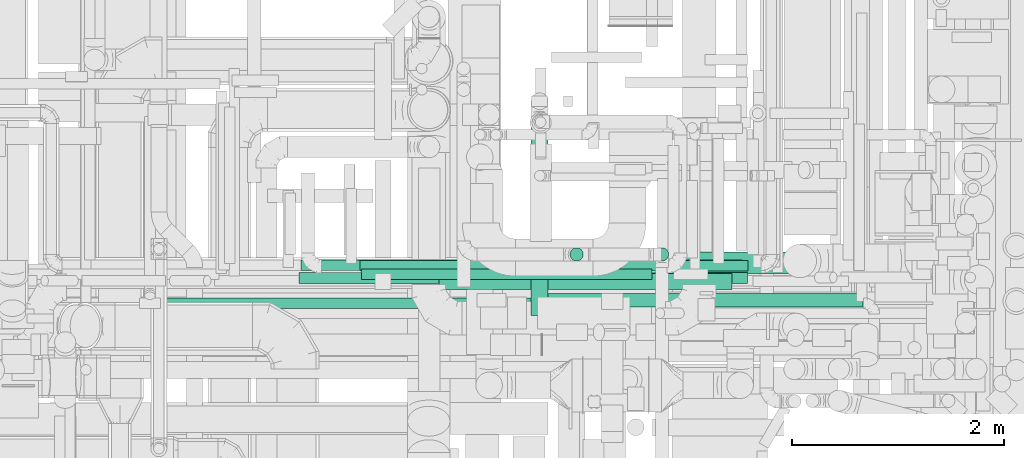
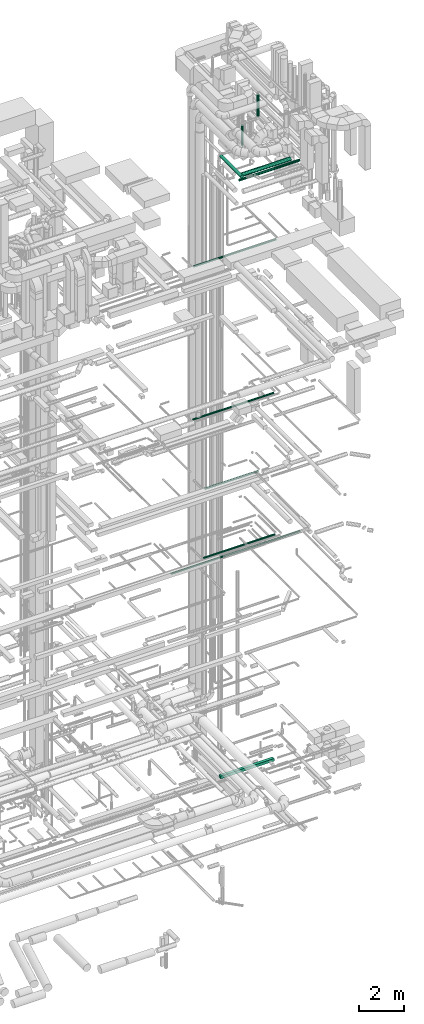
# One storey, part 65 of 337: 11 flow segments.
"""IFC2X3 building model written with IfcOpenShell, lengths in millimetres."""

import ifcopenshell
import ifcopenshell.guid

model = None  # the IFC model being written
_history = None  # IfcOwnerHistory: only IFC2X3 demands one
_inside = {}  # id of a spatial element -> (the spatial element, [elements in it])
_under = {}  # id of a project, library or spatial element -> (it, [spatial elements below it])
_declared = {}  # id of a project -> (the project, [libraries it declares])
_typed = {}  # id of a type object -> (the type object, [elements of that type])
_made_of = {}  # id of a material, layer set ... -> (it, [elements and type objects made of it])


def new_model(schema):
    """Start an empty IFC model of exactly this schema.

    Asked for "IFC4X3", IfcOpenShell would pick the latest addendum, in which some entities
    have other attributes; the version numbers below select the first issue.
    IFC2X3 requires an IfcOwnerHistory on every rooted entity: one is made here for all.
    """
    global model, _history
    if schema == "IFC4X3":
        model = ifcopenshell.file(schema_version=(4, 3, 0, 0))
    else:
        model = ifcopenshell.file(schema=schema)
    _inside.clear()
    _under.clear()
    _declared.clear()
    _typed.clear()
    _made_of.clear()
    _history = None
    if model.schema == "IFC2X3":
        org = make("IfcOrganization", Name="unknown")
        user = make(
            "IfcPersonAndOrganization",
            ThePerson=make("IfcPerson", FamilyName="unknown"),
            TheOrganization=org,
        )
        app = make(
            "IfcApplication",
            ApplicationDeveloper=org,
            Version="unknown",
            ApplicationFullName="unknown",
            ApplicationIdentifier="unknown",
        )
        _history = make(
            "IfcOwnerHistory",
            OwningUser=user,
            OwningApplication=app,
            ChangeAction="ADDED",
            CreationDate=0,
        )
    return model


def make(cls, **values):
    """One entity of the class cls with the attributes given. An attribute that is None is left unset."""
    return model.create_entity(
        cls, **{name: value for name, value in values.items() if value is not None}
    )


def entity(cls, *values):
    """Any entity or typed value of the class cls, its attributes in the order of the schema. None: left unset."""
    e = model.create_entity(cls)
    for i, value in enumerate(values):
        if value is not None:
            e[i] = value
    return e


def rooted(cls, **values):
    """An entity with a GlobalId (a new one), such as an element, a storey or a relation."""
    return make(cls, GlobalId=ifcopenshell.guid.new(), OwnerHistory=_history, **values)


def si_unit(unit_type, name, prefix=None):
    """IfcSIUnit, for example si_unit("LENGTHUNIT", "METRE", prefix="MILLI")."""
    return make("IfcSIUnit", UnitType=unit_type, Prefix=prefix, Name=name)


def converted_unit(unit_type, name, factor, base, dimensions=None, offset=None):
    """IfcConversionBasedUnit, such as the inch: factor (a typed value) times the base unit."""
    return make(
        "IfcConversionBasedUnit"
        if offset is None
        else "IfcConversionBasedUnitWithOffset",
        ConversionOffset=offset,
        Dimensions=None
        if dimensions is None
        else entity("IfcDimensionalExponents", *dimensions),
        UnitType=unit_type,
        Name=name,
        ConversionFactor=make(
            "IfcMeasureWithUnit", ValueComponent=factor, UnitComponent=base
        ),
    )


def derived_unit(unit_type, elements):
    """IfcDerivedUnit: a product of units, each with its exponent."""
    return make(
        "IfcDerivedUnit",
        Elements=[
            make("IfcDerivedUnitElement", Unit=unit, Exponent=power)
            for unit, power in elements
        ],
        UnitType=unit_type,
    )


def assignment(units):
    """IfcUnitAssignment: the units of a project."""
    return None if units is None else make("IfcUnitAssignment", Units=units)


def point(xyz):
    """IfcCartesianPoint."""
    return None if xyz is None else make("IfcCartesianPoint", Coordinates=xyz)


def direction(xyz):
    """IfcDirection."""
    return None if xyz is None else make("IfcDirection", DirectionRatios=xyz)


def frame(location, z_axis=None, x_axis=None):
    """IfcAxis2Placement3D, a coordinate frame: its origin and axes. An axis left out is left unset."""
    return make(
        "IfcAxis2Placement3D",
        Location=point(location),
        Axis=direction(z_axis),
        RefDirection=direction(x_axis),
    )


def frame_2d(location, x_axis=None):
    """IfcAxis2Placement2D, a coordinate frame in the plane: its origin and x axis."""
    return make(
        "IfcAxis2Placement2D", Location=point(location), RefDirection=direction(x_axis)
    )


def origin():
    """The frame at (0, 0, 0) with its axes left unset."""
    return frame((0.0, 0.0, 0.0))


def origin_2d_with_axis():
    """The frame at (0, 0) in the plane with the x axis (1, 0) written out."""
    return frame_2d((0.0, 0.0), x_axis=(1.0, 0.0))


def place(relative_to, where):
    """IfcLocalPlacement: puts the frame where relative to a parent placement (None: the world)."""
    return make(
        "IfcLocalPlacement", PlacementRelTo=relative_to, RelativePlacement=where
    )


def context(
    kind, dimensions, precision=None, world=None, true_north=None, identifier=None
):
    """IfcGeometricRepresentationContext, for example the 3D "Model" context."""
    return make(
        "IfcGeometricRepresentationContext",
        ContextIdentifier=identifier,
        ContextType=kind,
        CoordinateSpaceDimension=dimensions,
        Precision=precision,
        WorldCoordinateSystem=world,
        TrueNorth=true_north,
    )


def subcontext(parent, identifier, kind, view, scale=None):
    """IfcGeometricRepresentationSubContext, for example "Body" below "Model"."""
    return make(
        "IfcGeometricRepresentationSubContext",
        ContextIdentifier=identifier,
        ContextType=kind,
        ParentContext=parent,
        TargetScale=scale,
        TargetView=view,
    )


def project(units=None, contexts=None):
    """IfcProject with its units and contexts."""
    return rooted(
        "IfcProject",
        Name="project",
        RepresentationContexts=contexts,
        UnitsInContext=assignment(units),
    )


def spatial(cls, under=None, at=None, **own):
    """A site, building, storey or space (cls), placed at a placement, below another one or the project."""
    s = rooted(cls, ObjectPlacement=at, **own)
    if under is not None:
        _under.setdefault(under.id(), (under, []))[1].append(s)
    return s


def profile(cls, at=None, kind="AREA", **sizes):
    """A parametric profile (cls). Its sizes go by their IFC names, for example OverallWidth=200.0."""
    return make(cls, ProfileType=kind, Position=at, **sizes)


def rectangle(**sizes):
    """IfcRectangleProfileDef."""
    return profile("IfcRectangleProfileDef", **sizes)


def circle(**sizes):
    """IfcCircleProfileDef."""
    return profile("IfcCircleProfileDef", **sizes)


def extrude(swept, where, along, depth):
    """IfcExtrudedAreaSolid: the profile swept, set in the frame where, extruded along a direction by depth."""
    return make(
        "IfcExtrudedAreaSolid",
        SweptArea=swept,
        Position=where,
        ExtrudedDirection=direction(along),
        Depth=depth,
    )


def shape(context_of_items, identifier, shape_type, items):
    """IfcShapeRepresentation: the items that make up one representation, for example the "Body"."""
    return make(
        "IfcShapeRepresentation",
        ContextOfItems=context_of_items,
        RepresentationIdentifier=identifier,
        RepresentationType=shape_type,
        Items=items,
    )


def made_of(thing, what):
    """Note that an element or type object is made of a material, layer set ...; save() writes the relation."""
    if what is not None:
        _made_of.setdefault(what.id(), (what, []))[1].append(thing)
    return thing


def type_object(cls, material=None, **own):
    """A type object (cls), such as IfcWallType, which elements share."""
    return made_of(rooted(cls, **own), material)


def element(
    cls,
    number,
    at=None,
    inside=None,
    cuts=None,
    type_object=None,
    material=None,
    context=None,
    identifier="Body",
    shape_type=None,
    held_by="IfcProductDefinitionShape",
    body=None,
    shapes=None,
    **own,
):
    """One element of the class cls, such as IfcWall. Its Tag is "e" and its number.

    at: its placement. inside: the storey or other place that contains it. cuts: it is an
    opening in that element (IfcRelVoidsElement). A single representation is given by context,
    identifier, shape_type and body (its items); several are given by shapes. held_by: the class
    of the entity that holds the representations. save() writes the other relations.
    """
    e = rooted(cls, Tag="e%d" % number, ObjectPlacement=at, **own)
    if body is not None:
        shapes = [shape(context, identifier, shape_type, body)]
    if shapes is not None:
        e.Representation = make(held_by, Representations=shapes)
    if inside is not None:
        _inside.setdefault(inside.id(), (inside, []))[1].append(e)
    if cuts is not None:
        rooted(
            "IfcRelVoidsElement", RelatingBuildingElement=cuts, RelatedOpeningElement=e
        )
    if type_object is not None:
        _typed.setdefault(type_object.id(), (type_object, []))[1].append(e)
    return made_of(e, material)


def aggregate(whole, parts):
    """IfcRelAggregates: a whole, such as a stair, and the parts it consists of."""
    return rooted("IfcRelAggregates", RelatingObject=whole, RelatedObjects=parts)


def save(model, path):
    """Write the relations noted so far, then the file.

    IfcRelAggregates (storeys below a building ...), IfcRelContainedInSpatialStructure (elements
    in a storey), IfcRelDefinesByType, IfcRelAssociatesMaterial and IfcRelDeclares: one each for
    every whole, place, type object, material and project.
    """
    for whole, parts in _under.values():
        aggregate(whole, parts)
    for where, things in _inside.values():
        rooted(
            "IfcRelContainedInSpatialStructure",
            RelatedElements=things,
            RelatingStructure=where,
        )
    for kind, things in _typed.values():
        rooted("IfcRelDefinesByType", RelatedObjects=things, RelatingType=kind)
    for what, things in _made_of.values():
        rooted("IfcRelAssociatesMaterial", RelatedObjects=things, RelatingMaterial=what)
    for by, libraries in _declared.values():
        rooted("IfcRelDeclares", RelatingContext=by, RelatedDefinitions=libraries)
    model.write(path)


model = new_model("IFC2X3")

# Units and contexts
model_context = context("Model", 3, precision=0.01, world=origin(), true_north=direction((6.12303176911189e-17, 1.0)))
body_context = subcontext(model_context, "Body", "Model", "MODEL_VIEW")
ifc_project = project(units=[si_unit("LENGTHUNIT", "METRE", prefix="MILLI"), si_unit("AREAUNIT", "SQUARE_METRE"), si_unit("VOLUMEUNIT", "CUBIC_METRE"), converted_unit("PLANEANGLEUNIT", "DEGREE", entity("IfcRatioMeasure", 0.0174532925199433), si_unit("PLANEANGLEUNIT", "RADIAN"), dimensions=[0, 0, 0, 0, 0, 0, 0]), si_unit("MASSUNIT", "GRAM", prefix="KILO"), derived_unit("MASSDENSITYUNIT", [(si_unit("MASSUNIT", "GRAM", prefix="KILO"), 1), (si_unit("LENGTHUNIT", "METRE"), -3)]), derived_unit("MOMENTOFINERTIAUNIT", [(si_unit("LENGTHUNIT", "METRE"), 4)]), si_unit("TIMEUNIT", "SECOND"), si_unit("FREQUENCYUNIT", "HERTZ"), si_unit("THERMODYNAMICTEMPERATUREUNIT", "DEGREE_CELSIUS"), derived_unit("THERMALTRANSMITTANCEUNIT", [(si_unit("MASSUNIT", "GRAM", prefix="KILO"), 1), (si_unit("THERMODYNAMICTEMPERATUREUNIT", "KELVIN"), -1), (si_unit("TIMEUNIT", "SECOND"), -3)]), derived_unit("VOLUMETRICFLOWRATEUNIT", [(si_unit("LENGTHUNIT", "METRE"), 3), (si_unit("TIMEUNIT", "SECOND"), -1)]), derived_unit("MASSFLOWRATEUNIT", [(si_unit("MASSUNIT", "GRAM", prefix="KILO"), 1), (si_unit("TIMEUNIT", "SECOND"), -1)]), derived_unit("ROTATIONALFREQUENCYUNIT", [(si_unit("TIMEUNIT", "SECOND"), -1)]), si_unit("ELECTRICCURRENTUNIT", "AMPERE"), si_unit("ELECTRICVOLTAGEUNIT", "VOLT"), si_unit("POWERUNIT", "WATT"), si_unit("FORCEUNIT", "NEWTON", prefix="KILO"), si_unit("ILLUMINANCEUNIT", "LUX"), si_unit("LUMINOUSFLUXUNIT", "LUMEN"), si_unit("LUMINOUSINTENSITYUNIT", "CANDELA"), derived_unit("USERDEFINED", [(si_unit("MASSUNIT", "GRAM", prefix="KILO"), -1), (si_unit("LENGTHUNIT", "METRE"), -2), (si_unit("TIMEUNIT", "SECOND"), 3), (si_unit("LUMINOUSFLUXUNIT", "LUMEN"), 1)]), derived_unit("LINEARVELOCITYUNIT", [(si_unit("LENGTHUNIT", "METRE"), 1), (si_unit("TIMEUNIT", "SECOND"), -1)]), si_unit("PRESSUREUNIT", "PASCAL"), derived_unit("USERDEFINED", [(si_unit("LENGTHUNIT", "METRE"), -2), (si_unit("MASSUNIT", "GRAM", prefix="KILO"), 1), (si_unit("TIMEUNIT", "SECOND"), -2)]), derived_unit("LINEARFORCEUNIT", [(si_unit("MASSUNIT", "GRAM", prefix="KILO"), 1), (si_unit("LENGTHUNIT", "METRE"), 1), (si_unit("TIMEUNIT", "SECOND"), -2), (si_unit("LENGTHUNIT", "METRE"), -1)]), derived_unit("PLANARFORCEUNIT", [(si_unit("MASSUNIT", "GRAM", prefix="KILO"), 1), (si_unit("LENGTHUNIT", "METRE"), 1), (si_unit("TIMEUNIT", "SECOND"), -2), (si_unit("LENGTHUNIT", "METRE"), -2)])], contexts=[model_context])

# Site, building, storey
site_placement = place(None, origin())
site = spatial("IfcSite", under=ifc_project, at=site_placement, CompositionType="ELEMENT")
building_placement = place(site_placement, origin())
building = spatial("IfcBuilding", under=site, at=building_placement, CompositionType="ELEMENT")
storey_placement = place(building_placement, origin())
storey = spatial("IfcBuildingStorey", under=building, at=storey_placement, CompositionType="ELEMENT", Elevation=0.0)

# Flow segments
duct_segment_type_1 = type_object("IfcDuctSegmentType", PredefinedType="NOTDEFINED")
flow_segment_1_placement = place(storey_placement, frame((67655.27, 10099.06, -625.0)))
element("IfcFlowSegment", 1, at=flow_segment_1_placement, inside=storey, type_object=duct_segment_type_1, context=body_context, shape_type="SweptSolid", body=[
    extrude(rectangle(XDim=2759.99999999994, YDim=150.000000000001, at=origin_2d_with_axis()), frame((1380.0, 75.0, 0.0)), (0.0, 0.0, 1.0), 150.0),
])
duct_segment_type_2 = type_object("IfcDuctSegmentType", PredefinedType="NOTDEFINED")
flow_segment_2_placement = place(storey_placement, frame((66927.88, 10188.76, 15248.4)))
element("IfcFlowSegment", 2, at=flow_segment_2_placement, inside=storey, type_object=duct_segment_type_2, context=body_context, shape_type="SweptSolid", body=[
    extrude(circle(Radius=50.0, at=origin_2d_with_axis()), frame((0.0, 51.6, 51.6), z_axis=(1.0, 0.0, 0.0), x_axis=(0.0, 1.0, 0.0)), (0.0, 0.0, 1.0), 2735.60477999998),
])
flow_segment_3_placement = place(storey_placement, frame((65032.48, 9915.2, 11468.4)))
element("IfcFlowSegment", 3, at=flow_segment_3_placement, inside=storey, type_object=duct_segment_type_2, context=body_context, shape_type="SweptSolid", body=[
    extrude(circle(Radius=50.0, at=origin_2d_with_axis()), frame((0.0, 51.6, 51.6), z_axis=(1.0, 0.0, 0.0), x_axis=(0.0, -1.0, 0.0)), (0.0, 0.0, 1.0), 6622.40426021215),
])
flow_segment_4_placement = place(storey_placement, frame((66913.1, 10269.73, 11448.4)))
element("IfcFlowSegment", 4, at=flow_segment_4_placement, inside=storey, type_object=duct_segment_type_2, context=body_context, shape_type="SweptSolid", body=[
    extrude(circle(Radius=50.0, at=origin_2d_with_axis()), frame((0.0, 51.6, 51.6), z_axis=(1.0, 0.0, 0.0), x_axis=(0.0, 1.0, 0.0)), (0.0, 0.0, 1.0), 3655.00000000002),
])
flow_segment_5_placement = place(storey_placement, frame((66354.82, 10273.6, 19148.4)))
element("IfcFlowSegment", 5, at=flow_segment_5_placement, inside=storey, type_object=duct_segment_type_2, context=body_context, shape_type="SweptSolid", body=[
    extrude(circle(Radius=50.0, at=origin_2d_with_axis()), frame((0.0, 51.6, 51.6), z_axis=(1.0, 0.0, 0.0), x_axis=(0.0, -1.0, 0.0)), (0.0, 0.0, 1.0), 4160.0),
])
flow_segment_6_placement = place(storey_placement, frame((69693.36, 10363.17, 34445.0)))
element("IfcFlowSegment", 6, at=flow_segment_6_placement, inside=storey, type_object=duct_segment_type_2, context=body_context, shape_type="SweptSolid", body=[
    extrude(circle(Radius=62.5, at=origin_2d_with_axis()), frame((64.1, 64.1, 0.0)), (0.0, 0.0, 1.0), 1180.0),
])
flow_segment_7_placement = place(storey_placement, frame((68888.36, 10363.17, 33140.0)))
element("IfcFlowSegment", 7, at=flow_segment_7_placement, inside=storey, type_object=duct_segment_type_2, context=body_context, shape_type="SweptSolid", body=[
    extrude(circle(Radius=62.5, at=origin_2d_with_axis()), frame((64.1, 64.1, 0.0)), (0.0, 0.0, 1.0), 1067.5),
])
flow_segment_8_placement = place(storey_placement, frame((66334.88, 10153.48, 27548.4)))
element("IfcFlowSegment", 8, at=flow_segment_8_placement, inside=storey, type_object=duct_segment_type_2, context=body_context, shape_type="SweptSolid", body=[
    extrude(circle(Radius=50.0, at=origin_2d_with_axis()), frame((0.0, 51.6, 51.6), z_axis=(1.0, 0.0, 0.0), x_axis=(0.0, 1.0, 0.0)), (0.0, 0.0, 1.0), 4230.00000000002),
])
flow_segment_9_placement = place(storey_placement, frame((68538.8, 9931.15, 31575.9)))
element("IfcFlowSegment", 9, at=flow_segment_9_placement, inside=storey, type_object=duct_segment_type_2, context=body_context, shape_type="SweptSolid", body=[
    extrude(circle(Radius=62.5, at=origin_2d_with_axis()), frame((0.0, 64.1, 64.1), z_axis=(1.0, 0.0, 0.0), x_axis=(0.0, 1.0, 0.0)), (0.0, 0.0, 1.0), 3110.0),
])
flow_segment_10_placement = place(storey_placement, frame((68813.63, 10246.82, 31498.4)))
element("IfcFlowSegment", 10, at=flow_segment_10_placement, inside=storey, type_object=duct_segment_type_2, context=body_context, shape_type="SweptSolid", body=[
    extrude(circle(Radius=100.0, at=origin_2d_with_axis()), frame((0.0, 101.6, 101.6), z_axis=(1.0, 0.0, 0.0), x_axis=(0.0, 1.0, 0.0)), (0.0, 0.0, 1.0), 2556.48096654397),
])
flow_segment_11_placement = place(storey_placement, frame((68522.63, 9853.42, 31818.4)))
element("IfcFlowSegment", 11, at=flow_segment_11_placement, inside=storey, type_object=duct_segment_type_2, context=body_context, shape_type="SweptSolid", body=[
    extrude(circle(Radius=80.0, at=origin_2d_with_axis()), frame((81.6, 0.0, 81.6), z_axis=(0.0, 1.0, 0.0), x_axis=(1.0, 0.0, 0.0)), (0.0, 0.0, 1.0), 1856.61002919929),
])

save(model, "model.ifc")
